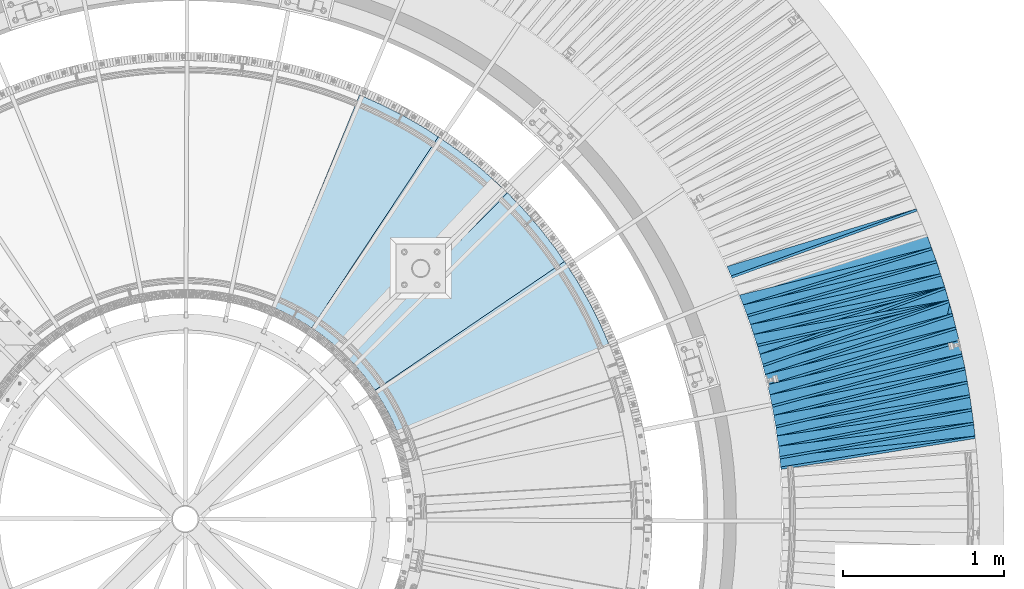
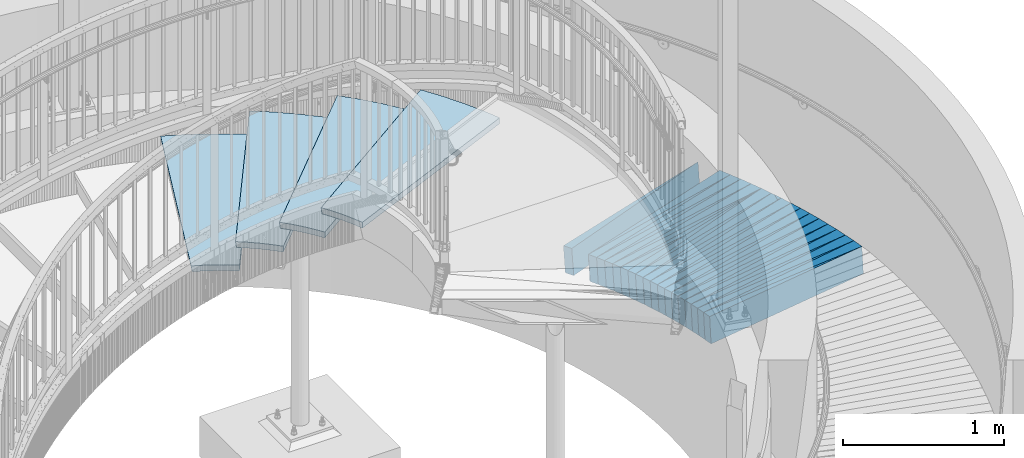
# One storey, part 835 of 975: 39 plates.
"""IFC2X3 building model written with IfcOpenShell, lengths in millimetres."""

from ifc_helpers import new_model, si_unit, frame, origin_with_axes, place, context, subcontext, project, spatial, faceted_brep, material, type_object, element, save


model = new_model("IFC2X3")

# Units and contexts
model_context = context("Model", 3, precision=1e-05, world=origin_with_axes())
body_context = subcontext(model_context, "Body", "Model", "MODEL_VIEW")
ifc_project = project(units=[si_unit("LENGTHUNIT", "METRE", prefix="MILLI"), si_unit("AREAUNIT", "SQUARE_METRE"), si_unit("VOLUMEUNIT", "CUBIC_METRE"), si_unit("MASSUNIT", "GRAM", prefix="KILO"), si_unit("TIMEUNIT", "SECOND"), si_unit("PLANEANGLEUNIT", "RADIAN"), si_unit("SOLIDANGLEUNIT", "STERADIAN"), si_unit("THERMODYNAMICTEMPERATUREUNIT", "DEGREE_CELSIUS"), si_unit("LUMINOUSINTENSITYUNIT", "LUMEN")], contexts=[model_context])

# Site, building, storey
site_placement = place(None, origin_with_axes())
site = spatial("IfcSite", under=ifc_project, at=site_placement, CompositionType="ELEMENT")
building_placement = place(site_placement, origin_with_axes())
building = spatial("IfcBuilding", under=site, at=building_placement, Name="Undefined", CompositionType="ELEMENT")
storey_placement = place(building_placement, origin_with_axes())
storey = spatial("IfcBuildingStorey", under=building, at=storey_placement, Name="Undefined", CompositionType="ELEMENT", Elevation=0.0)

# Plates
ifc_material_1 = material(Name="STEEL/A36")
plate_type_1 = type_object("IfcPlateType", PredefinedType="NOTDEFINED")
plate_1_placement = place(storey_placement, frame((39625.9824419077, 3998.43174738921, 426.0120271397), z_axis=(0.174232548959924, -0.983067229133674, 0.0567612710073381), x_axis=(-0.984686549821491, -0.174288045968404, 0.00400944299927316)))
element("IfcPlate", 1, at=plate_1_placement, inside=storey, type_object=plate_type_1, material=ifc_material_1, Name="SLAB", context=body_context, shape_type="Brep", body=[
    faceted_brep([(-6.82121026329696e-12, -100.000000000011, -1.09139364212751e-10), (6.05909538287233, -100.000000000004, 85.8984680175308), (6.05909538223204, 100.000000000001, 85.8984680176727), (5.91171556152403e-12, 100.000000000011, 1.09139364212751e-10), (1222.11474609037, -100.000000000009, 2.81397660728544e-09), (1222.11474608972, 99.9999999999958, 2.95494828606024e-09)], [[[0, 1, 2, 3]], [[1, 4, 5, 2]], [[4, 0, 3, 5]], [[5, 3, 2]], [[4, 1, 0]]]),
])
plate_2_placement = place(storey_placement, frame((39614.0804281054, 4083.64656523425, 421.111820499393), z_axis=(0.191444695794336, -0.979862872955085, 0.056724585996033), x_axis=(-0.981478928972378, -0.19152806399461, 0.00401406099988702)))
element("IfcPlate", 2, at=plate_2_placement, inside=storey, type_object=plate_type_1, material=ifc_material_1, Name="SLAB", context=body_context, shape_type="Brep", body=[
    faceted_brep([(-6.82121026329696e-12, -100.000000000011, -1.09139364212751e-10), (4.56011295288772, -100.000000000002, 86.0596008301241), (4.56011295317148, 100.0, 86.0596008300795), (5.91171556152403e-12, 100.000000000011, 1.09139364212751e-10), (1220.70886230643, -100.000000000039, -9.09949449123815e-10), (1220.70886230672, 99.9999999999637, -9.54059942159802e-10)], [[[0, 1, 2, 3]], [[1, 4, 5, 2]], [[4, 0, 3, 5]], [[5, 3, 2]], [[4, 1, 0]]]),
])
plate_3_placement = place(storey_placement, frame((39602.1949631265, 4168.745903443, 416.118423112002), z_axis=(0.208477679916396, -0.976313562950722, 0.0578695409964878), x_axis=(-0.977993776870184, -0.208593936972311, 0.00409168199945686)))
element("IfcPlate", 3, at=plate_3_placement, inside=storey, type_object=plate_type_1, material=ifc_material_1, Name="SLAB", context=body_context, shape_type="Brep", body=[
    faceted_brep([(-6.82121026329696e-12, -100.000000000011, -1.09139364212751e-10), (6.05673646894866, -99.9999999999937, 85.9729919434467), (6.05673646956711, 99.9999999999984, 85.9729919433266), (5.91171556152403e-12, 100.000000000011, 1.09139364212751e-10), (1221.99145507645, -99.9999999999583, 4.94401319883764e-09), (1221.99145507707, 100.000000000034, 4.82486939290538e-09)], [[[0, 1, 2, 3]], [[1, 4, 5, 2]], [[4, 0, 3, 5]], [[5, 3, 2]], [[4, 1, 0]]]),
])
plate_4_placement = place(storey_placement, frame((39587.3777138571, 4253.57169134227, 411.211967734843), z_axis=(0.225549249934069, -0.972577460815426, 0.0567504939890238), x_axis=(-0.974191077270086, -0.22568923806257, 0.00401407400111285)))
element("IfcPlate", 4, at=plate_4_placement, inside=storey, type_object=plate_type_1, material=ifc_material_1, Name="SLAB", context=body_context, shape_type="Brep", body=[
    faceted_brep([(-6.82121026329696e-12, -100.000000000011, -1.09139364212751e-10), (4.62010049822857, -100.0, 86.016075134231), (4.62010049857054, 99.9999999999967, 86.0160751341682), (5.91171556152403e-12, 100.000000000011, 1.09139364212751e-10), (1220.70507812274, -100.000000000071, -9.877112461254e-10), (1220.705078123, 99.9999999999361, -8.85847839526832e-10)], [[[0, 1, 2, 3]], [[1, 4, 5, 2]], [[4, 0, 3, 5]], [[5, 3, 2]], [[4, 1, 0]]]),
])
plate_5_placement = place(storey_placement, frame((39572.5968935966, 4338.06844142463, 406.218966547519), z_axis=(0.242357914820925, -0.968453872958731, 0.0579632389958235), x_axis=(-0.970134380603416, -0.242533594900854, 0.00409132199832751)))
element("IfcPlate", 5, at=plate_5_placement, inside=storey, type_object=plate_type_1, material=ifc_material_1, Name="SLAB", context=body_context, shape_type="Brep", body=[
    faceted_brep([(-6.82121026329696e-12, -100.000000000011, -1.09139364212751e-10), (6.08379650064307, -99.9999999999922, 85.8321456910589), (6.08379650125426, 100.000000000003, 85.8321456909125), (5.91171556152403e-12, 100.000000000011, 1.09139364212751e-10), (1222.09875488287, -99.9999999999768, 6.83940015733242e-10), (1222.09875488291, 100.000000000027, 8.29459168016911e-10)], [[[0, 1, 2, 3]], [[1, 4, 5, 2]], [[4, 0, 3, 5]], [[5, 3, 2]], [[4, 1, 0]]]),
])
plate_6_placement = place(storey_placement, frame((39554.79502433, 4422.19130410845, 401.218699276603), z_axis=(0.259235288096985, -0.964076087687476, 0.0579168589832336), x_axis=(-0.965750673638308, -0.259439509902835, 0.00409598199846596)))
element("IfcPlate", 6, at=plate_6_placement, inside=storey, type_object=plate_type_1, material=ifc_material_1, Name="SLAB", context=body_context, shape_type="Brep", body=[
    faceted_brep([(-6.82121026329696e-12, -100.000000000011, -1.09139364212751e-10), (4.55240583407249, -100.000000000034, 86.0086975093363), (4.55240583426712, 100.000000000015, 86.0086975099912), (5.91171556152403e-12, 100.000000000011, 1.09139364212751e-10), (1220.7084960928, -100.000000000221, -1.74622982740402e-09), (1220.708496093, 99.9999999998272, -1.09139364212751e-09)], [[[0, 1, 2, 3]], [[1, 4, 5, 2]], [[4, 0, 3, 5]], [[5, 3, 2]], [[4, 1, 0]]]),
])
plate_7_placement = place(storey_placement, frame((39536.9846772555, 4506.41710653635, 396.218264542999), z_axis=(0.276024998064779, -0.95940875384129, 0.057836350991757), x_axis=(-0.961075872682364, -0.276253055908699, 0.00417325399862075)))
element("IfcPlate", 7, at=plate_7_placement, inside=storey, type_object=plate_type_1, material=ifc_material_1, Name="SLAB", context=body_context, shape_type="Brep", body=[
    faceted_brep([(-6.82121026329696e-12, -100.000000000011, -1.09139364212751e-10), (6.07811546346784, -99.9999999999997, 86.012245178159), (6.07811546326411, 100.000000000002, 86.0122451782854), (5.91171556152403e-12, 100.000000000011, 1.09139364212751e-10), (1222.06787109673, -100.000000000031, 1.97815097635612e-09), (1222.06787109653, 99.9999999999707, 2.10366124520078e-09)], [[[0, 1, 2, 3]], [[1, 4, 5, 2]], [[4, 0, 3, 5]], [[5, 3, 2]], [[4, 1, 0]]]),
])
plate_8_placement = place(storey_placement, frame((39516.2599873774, 4589.94244293884, 391.312151865691), z_axis=(0.292758928776712, -0.954499123331264, 0.0567770480155632), x_axis=(-0.956101584764134, -0.293006799927716, 0.00409570599898962)))
element("IfcPlate", 8, at=plate_8_placement, inside=storey, type_object=plate_type_1, material=ifc_material_1, Name="SLAB", context=body_context, shape_type="Brep", body=[
    faceted_brep([(-6.82121026329696e-12, -100.000000000011, -1.09139364212751e-10), (4.56992292403447, -99.9999999999974, 85.9728164673306), (4.56992292365612, 100.000000000001, 85.9728164674088), (5.91171556152403e-12, 100.000000000011, 1.09139364212751e-10), (1220.7907714854, -99.999999999976, 2.13913153856993e-09), (1220.79077148502, 100.000000000022, 2.21643858822063e-09)], [[[0, 1, 2, 3]], [[1, 4, 5, 2]], [[4, 0, 3, 5]], [[5, 3, 2]], [[4, 1, 0]]]),
])
plate_9_placement = place(storey_placement, frame((39495.5906041289, 4673.36243128371, 386.318381136643), z_axis=(0.309347422665189, -0.949187086009158, 0.05786231799581), x_axis=(-0.950845544943423, -0.309638514981577, 0.00409141799975657)))
element("IfcPlate", 9, at=plate_9_placement, inside=storey, type_object=plate_type_1, material=ifc_material_1, Name="SLAB", context=body_context, shape_type="Brep", body=[
    faceted_brep([(-6.82121026329696e-12, -100.000000000011, -1.09139364212751e-10), (6.09768581410026, -100.000000000004, 85.9808578490283), (6.09768581418029, 100.000000000003, 85.9808578490811), (5.91171556152403e-12, 100.000000000011, 1.09139364212751e-10), (1222.07019043372, -100.000000000019, 8.43101588543504e-10), (1222.0701904338, 99.9999999999876, 8.95852281246334e-10)], [[[0, 1, 2, 3]], [[1, 4, 5, 2]], [[4, 0, 3, 5]], [[5, 3, 2]], [[4, 1, 0]]]),
])
plate_10_placement = place(storey_placement, frame((39471.9612434175, 4756.09113765538, 381.412225927542), z_axis=(0.325901786052775, -0.943696059324096, 0.0567958930186322), x_axis=(-0.945288728200497, -0.32621021906919, 0.00401413900085143)))
element("IfcPlate", 10, at=plate_10_placement, inside=storey, type_object=plate_type_1, material=ifc_material_1, Name="SLAB", context=body_context, shape_type="Brep", body=[
    faceted_brep([(-6.82121026329696e-12, -100.000000000011, -1.09139364212751e-10), (4.56129026379494, -100.000000000001, 85.9514694214504), (4.56129026418057, 99.9999999999982, 85.9514694213831), (5.91171556152403e-12, 100.000000000011, 1.09139364212751e-10), (1220.68530273628, -100.000000000019, 1.44973455462605e-09), (1220.68530273665, 99.9999999999799, 1.38061295729131e-09)], [[[0, 1, 2, 3]], [[1, 4, 5, 2]], [[4, 0, 3, 5]], [[5, 3, 2]], [[4, 1, 0]]]),
])
plate_11_placement = place(storey_placement, frame((39448.386584414, 4838.7133624584, 376.418469865489), z_axis=(0.342264877537244, -0.937819243784971, 0.057877625996593), x_axis=(-0.939467395749397, -0.342613882908607, 0.0040914009989086)))
element("IfcPlate", 11, at=plate_11_placement, inside=storey, type_object=plate_type_1, material=ifc_material_1, Name="SLAB", context=body_context, shape_type="Brep", body=[
    faceted_brep([(-6.82121026329696e-12, -100.000000000011, -1.09139364212751e-10), (6.08924770340673, -99.9999999999915, 85.9587173463115), (6.08924770363228, 99.9999999999977, 85.9587173461441), (5.91171556152403e-12, 100.000000000011, 1.09139364212751e-10), (1222.07543945396, -100.000000000037, -1.40244083013386e-09), (1222.07543945419, 99.999999999952, -1.56978785526007e-09)], [[[0, 1, 2, 3]], [[1, 4, 5, 2]], [[4, 0, 3, 5]], [[5, 3, 2]], [[4, 1, 0]]]),
])
plate_12_placement = place(storey_placement, frame((39472.2029686441, 4756.06143704428, 381.390397208628), z_axis=(0.22368990115793, -0.972939875342943, 0.057886329021748), x_axis=(-0.974512642012384, -0.22429519300285, -0.00409596800005203)))
element("IfcPlate", 12, at=plate_12_placement, inside=storey, type_object=plate_type_1, material=ifc_material_1, Name="SLAB", context=body_context, shape_type="Brep", body=[
    faceted_brep([(-6.82121026329696e-12, -100.000000000011, -1.09139364212751e-10), (-4.56721687257232, -100.000000000017, 86.0530090329958), (-4.56721687326353, 100.000000000002, 86.053009033214), (5.91171556152403e-12, 100.000000000011, 1.09139364212751e-10), (1220.71276855146, -99.9999999999328, -3.9744918467477e-10), (1220.71276855077, 100.000000000086, -1.79170456249267e-10)], [[[0, 1, 2, 3]], [[1, 4, 5, 2]], [[4, 0, 3, 5]], [[5, 3, 2]], [[4, 1, 0]]]),
])
plate_13_placement = place(storey_placement, frame((39448.5926548318, 4838.78714752327, 376.390536032474), z_axis=(0.240768893784589, -0.968852951319953, 0.0579163060317441), x_axis=(-0.970418033367917, -0.241397521091522, -0.00400965400152018)))
element("IfcPlate", 13, at=plate_13_placement, inside=storey, type_object=plate_type_1, material=ifc_material_1, Name="SLAB", context=body_context, shape_type="Brep", body=[
    faceted_brep([(-6.82121026329696e-12, -100.000000000011, -1.09139364212751e-10), (-3.05538058281672, -100.000000000003, 86.1199417113758), (-3.05538058237289, 99.9999999999897, 86.1199417113066), (5.91171556152403e-12, 100.000000000011, 1.09139364212751e-10), (1222.05065917552, -99.9999999999858, 4.12273948313668e-09), (1222.05065917598, 100.000000000007, 4.05361788580194e-09)], [[[0, 1, 2, 3]], [[1, 4, 5, 2]], [[4, 0, 3, 5]], [[5, 3, 2]], [[4, 1, 0]]]),
])
plate_14_placement = place(storey_placement, frame((39422.066176282, 4920.73525767463, 371.483793850987), z_axis=(0.257572832400976, -0.964591757229109, 0.0567360370011757), x_axis=(-0.966079833699057, -0.258211110919565, -0.00409598799872405)))
element("IfcPlate", 14, at=plate_14_placement, inside=storey, type_object=plate_type_1, material=ifc_material_1, Name="SLAB", context=body_context, shape_type="Brep", body=[
    faceted_brep([(-6.82121026329696e-12, -100.000000000011, -1.09139364212751e-10), (-4.59612512584135, -100.000000000003, 86.0330505371167), (-4.59612512593594, 99.9999999999959, 86.0330505370575), (5.91171556152403e-12, 100.000000000011, 1.09139364212751e-10), (1220.70654296677, -100.000000000073, 1.41517375595868e-09), (1220.70654296638, 99.9999999999, 1.13868736661971e-09)], [[[0, 1, 2, 3]], [[1, 4, 5, 2]], [[4, 0, 3, 5]], [[5, 3, 2]], [[4, 1, 0]]]),
])
plate_15_placement = place(storey_placement, frame((39395.5922700244, 5002.45462566311, 366.490597049088), z_axis=(0.27442047009075, -0.959863819145956, 0.0579211040097828), x_axis=(-0.96140465762622, -0.275107877893042, -0.00409143199840933)))
element("IfcPlate", 15, at=plate_15_placement, inside=storey, type_object=plate_type_1, material=ifc_material_1, Name="SLAB", context=body_context, shape_type="Brep", body=[
    faceted_brep([(-6.82121026329696e-12, -100.000000000011, -1.09139364212751e-10), (-3.08999657691311, -99.999999999991, 86.1060485840826), (-3.08999657622189, 99.9999999999988, 86.1060485839635), (5.91171556152403e-12, 100.000000000011, 1.09139364212751e-10), (1222.06604003649, -99.9999999999675, -8.78571881912649e-10), (1222.0660400372, 100.000000000023, -9.97715687844902e-10)], [[[0, 1, 2, 3]], [[1, 4, 5, 2]], [[4, 0, 3, 5]], [[5, 3, 2]], [[4, 1, 0]]]),
])
plate_16_placement = place(storey_placement, frame((39366.2791004726, 5083.28751788098, 361.490570024016), z_axis=(0.291006833646104, -0.954966010400153, 0.0579218590143898), x_axis=(-0.956496360066036, -0.291716644020139, -0.00401407300027713)))
element("IfcPlate", 16, at=plate_16_placement, inside=storey, type_object=plate_type_1, material=ifc_material_1, Name="SLAB", context=body_context, shape_type="Brep", body=[
    faceted_brep([(-6.82121026329696e-12, -100.000000000011, -1.09139364212751e-10), (-4.5703582764545, -99.999999999996, 86.0064620972498), (-4.57035827682557, 100.000000000005, 86.0064620972753), (5.91171556152403e-12, 100.000000000011, 1.09139364212751e-10), (1220.70507812274, -100.000000000071, -9.877112461254e-10), (1220.705078123, 99.9999999999361, -8.85847839526832e-10)], [[[0, 1, 2, 3]], [[1, 4, 5, 2]], [[4, 0, 3, 5]], [[5, 3, 2]], [[4, 1, 0]]]),
])
plate_17_placement = place(storey_placement, frame((39336.9385057262, 5164.23229206698, 356.584061502682), z_axis=(0.307720273152248, -0.949780613140639, 0.0567892630106877), x_axis=(-0.951237885653077, -0.308432173887512, -0.00400986399853756)))
element("IfcPlate", 17, at=plate_17_placement, inside=storey, type_object=plate_type_1, material=ifc_material_1, Name="SLAB", context=body_context, shape_type="Brep", body=[
    faceted_brep([(-6.82121026329696e-12, -100.000000000011, -1.09139364212751e-10), (-3.06472253797256, -99.9999999999985, 86.0675201415606), (-3.06472253784159, 99.9999999999941, 86.0675201415261), (5.91171556152403e-12, 100.000000000011, 1.09139364212751e-10), (1221.98669433537, -99.9999999999605, 4.74665284855291e-09), (1221.98669433551, 100.000000000032, 4.710273060482e-09)], [[[0, 1, 2, 3]], [[1, 4, 5, 2]], [[4, 0, 3, 5]], [[5, 3, 2]], [[4, 1, 0]]]),
])
plate_type_2 = type_object("IfcPlateType", PredefinedType="NOTDEFINED")
plate_18_placement = place(storey_placement, frame((39635.1936692544, 3910.9231824116, 431.047656661723), z_axis=(0.104275265094708, -0.991555543506223, 0.0770991130396971), x_axis=(-0.994515785968049, -0.10458657399664, 0.0)))
element("IfcPlate", 18, at=plate_18_placement, inside=storey, type_object=plate_type_2, material=ifc_material_1, Name="SLAB", context=body_context, shape_type="Brep", body=[
    faceted_brep([(-6.82121026329696e-12, -100.000000000011, -1.09139364212751e-10), (1219.04797363422, -100.000000000019, 64.8515853879779), (1219.04797363403, 99.9999999999873, 64.851585387998), (5.91171556152403e-12, 100.000000000011, 1.09139364212751e-10), (1219.08569336095, -100.00000000002, -8.19056822365383e-10), (1219.08569336076, 99.9999999999858, -7.98536348156631e-10)], [[[0, 1, 2, 3]], [[1, 4, 5, 2]], [[4, 0, 3, 5]], [[5, 3, 2]], [[4, 1, 0]]]),
])
plate_19_placement = place(storey_placement, frame((39626.3072442472, 3996.59952477286, 426.135234977188), z_axis=(0.121536557548468, -0.989713242079951, 0.0754755830110665), x_axis=(-0.992544325654003, -0.121884213957511, 0.0)))
element("IfcPlate", 19, at=plate_19_placement, inside=storey, type_object=plate_type_2, material=ifc_material_1, Name="SLAB", context=body_context, shape_type="Brep", body=[
    faceted_brep([(-6.82121026329696e-12, -100.000000000011, -1.09139364212751e-10), (1220.38916015246, -99.9999999999725, 64.9216613772952), (1220.38916015196, 100.000000000032, 64.9216613773524), (5.91171556152403e-12, 100.000000000011, 1.09139364212751e-10), (1219.18994140627, -100.000000000053, -7.20319803804159e-10), (1219.18994140625, 99.9999999999468, -8.36735125631094e-10)], [[[0, 1, 2, 3]], [[1, 4, 5, 2]], [[4, 0, 3, 5]], [[5, 3, 2]], [[4, 1, 0]]]),
])
plate_20_placement = place(storey_placement, frame((39614.4381807975, 4081.81586191426, 421.235302887626), z_axis=(0.138818678071955, -0.987436811432201, 0.0754845550226188), x_axis=(-0.990262057711787, -0.139215864959482, 0.0)))
element("IfcPlate", 20, at=plate_20_placement, inside=storey, type_object=plate_type_2, material=ifc_material_1, Name="SLAB", context=body_context, shape_type="Brep", body=[
    faceted_brep([(-6.82121026329696e-12, -100.000000000011, -1.09139364212751e-10), (1218.98168945343, -99.9999999999906, 64.9139404298153), (1218.98168945358, 100.00000000001, 64.9139404298273), (5.91171556152403e-12, 100.000000000011, 1.09139364212751e-10), (1218.97021484425, -99.9999999999932, -2.70483724307269e-09), (1218.9702148444, 100.000000000007, -2.69142219622154e-09)], [[[0, 1, 2, 3]], [[1, 4, 5, 2]], [[4, 0, 3, 5]], [[5, 3, 2]], [[4, 1, 0]]]),
])
plate_21_placement = place(storey_placement, frame((39602.5928489666, 4166.88293776894, 416.247106581318), z_axis=(0.156040928598268, -0.984742567447247, 0.0770279459650556), x_axis=(-0.987677020910883, -0.156505917985879, 0.0)))
element("IfcPlate", 21, at=plate_21_placement, inside=storey, type_object=plate_type_2, material=ifc_material_1, Name="SLAB", context=body_context, shape_type="Brep", body=[
    faceted_brep([(-6.82121026329696e-12, -100.000000000011, -1.09139364212751e-10), (1220.26611327869, -99.9999999999883, 64.9115066529448), (1220.26611327819, 100.000000000018, 64.9115066530658), (5.91171556152403e-12, 100.000000000011, 1.09139364212751e-10), (1219.12329101291, -99.9999999999872, 1.9990693544969e-09), (1219.12329101241, 100.00000000002, 2.1200321498327e-09)], [[[0, 1, 2, 3]], [[1, 4, 5, 2]], [[4, 0, 3, 5]], [[5, 3, 2]], [[4, 1, 0]]]),
])
plate_22_placement = place(storey_placement, frame((39587.7994994513, 4251.75324628954, 411.335603814503), z_axis=(0.173246999798132, -0.981978389669941, 0.0755242959727249), x_axis=(-0.984790990276387, -0.173743217048762, 0.0)))
element("IfcPlate", 22, at=plate_22_placement, inside=storey, type_object=plate_type_2, material=ifc_material_1, Name="SLAB", context=body_context, shape_type="Brep", body=[
    faceted_brep([(-6.82121026329696e-12, -100.000000000011, -1.09139364212751e-10), (1218.97973632623, -100.000000000001, 64.8797836303711), (1218.97973632606, 99.9999999999978, 64.879783630357), (5.91171556152403e-12, 100.000000000011, 1.09139364212751e-10), (1219.04040527135, -99.9999999999979, 3.58977558789775e-09), (1219.04040527118, 100.000000000001, 3.57613316737115e-09)], [[[0, 1, 2, 3]], [[1, 4, 5, 2]], [[4, 0, 3, 5]], [[5, 3, 2]], [[4, 1, 0]]]),
])
plate_23_placement = place(storey_placement, frame((39573.0558259939, 4336.23486631698, 406.3466842114), z_axis=(0.190215824337771, -0.978720112202225, 0.0769732560203004), x_axis=(-0.981632460760012, -0.190781843953358, 0.0)))
element("IfcPlate", 23, at=plate_23_placement, inside=storey, type_object=plate_type_2, material=ifc_material_1, Name="SLAB", context=body_context, shape_type="Brep", body=[
    faceted_brep([(-6.82121026329696e-12, -100.000000000011, -1.09139364212751e-10), (1220.37121581964, -100.000000000275, 64.9576263392737), (1220.3712158196, 99.9999999997194, 64.9576263391209), (5.91171556152403e-12, 100.000000000011, 1.09139364212751e-10), (1219.19360351495, -100.00000000027, -7.08678271621466e-09), (1219.19360351492, 99.9999999997235, -7.23230186849833e-09)], [[[0, 1, 2, 3]], [[1, 4, 5, 2]], [[4, 0, 3, 5]], [[5, 3, 2]], [[4, 1, 0]]]),
])
plate_24_placement = place(storey_placement, frame((39555.2485426552, 4420.50494634474, 401.3353492434), z_axis=(0.207283429834701, -0.975363903392586, 0.0754906330264907), x_axis=(-0.978156345823696, -0.207870527962532, 8.20329999852089e-05)))
element("IfcPlate", 24, at=plate_24_placement, inside=storey, type_object=plate_type_2, material=ifc_material_1, Name="SLAB", context=body_context, shape_type="Brep", body=[
    faceted_brep([(-6.82121026329696e-12, -100.000000000011, -1.09139364212751e-10), (1218.98156738237, -100.000000000005, 64.9087677006019), (1218.98156738291, 99.9999999999862, 64.9087677004409), (5.91171556152403e-12, 100.000000000011, 1.09139364212751e-10), (1219.02807616998, -100.0, -6.25732354819775e-10), (1219.02807616998, 100.0, -6.25732354819775e-10)], [[[0, 1, 2, 3]], [[1, 4, 5, 2]], [[4, 0, 3, 5]], [[5, 3, 2]], [[4, 1, 0]]]),
])
plate_25_placement = place(storey_placement, frame((39537.5123529006, 4504.58328601841, 396.3471348594), z_axis=(0.224310998257453, -0.971468329136015, 0.0770315620146961), x_axis=(-0.974364921798821, -0.224973314953549, 8.20169999830688e-05)))
element("IfcPlate", 25, at=plate_25_placement, inside=storey, type_object=plate_type_2, material=ifc_material_1, Name="SLAB", context=body_context, shape_type="Brep", body=[
    faceted_brep([(-6.82121026329696e-12, -100.000000000011, -1.09139364212751e-10), (1220.34301757949, -100.000000000041, 64.9073028563771), (1220.34301757914, 99.999999999971, 64.9073028565372), (5.91171556152403e-12, 100.000000000011, 1.09139364212751e-10), (1219.25573730616, -100.000000000041, -3.66890162695199e-09), (1219.25573730582, 99.9999999999716, -3.50883055943996e-09)], [[[0, 1, 2, 3]], [[1, 4, 5, 2]], [[4, 0, 3, 5]], [[5, 3, 2]], [[4, 1, 0]]]),
])
plate_26_placement = place(storey_placement, frame((39516.8510490228, 4588.01565535995, 391.447198894502), z_axis=(0.241198931711602, -0.967413009126454, 0.0770398930040898), x_axis=(-0.970296720224289, -0.24191790905592, 0.0)))
element("IfcPlate", 26, at=plate_26_placement, inside=storey, type_object=plate_type_2, material=ifc_material_1, Name="SLAB", context=body_context, shape_type="Brep", body=[
    faceted_brep([(-6.82121026329696e-12, -100.000000000011, -1.09139364212751e-10), (1219.06433105493, -100.00000000003, 64.9014434810633), (1219.06433105533, 99.9999999999663, 64.9014434810188), (5.91171556152403e-12, 100.000000000011, 1.09139364212751e-10), (1219.0085449224, -99.9999999998281, 1.32422428578138e-09), (1219.00854492224, 100.000000000115, 6.83940015733242e-10)], [[[0, 1, 2, 3]], [[1, 4, 5, 2]], [[4, 0, 3, 5]], [[5, 3, 2]], [[4, 1, 0]]]),
])
plate_27_placement = place(storey_placement, frame((39496.1819606158, 4671.54818273382, 386.447298540808), z_axis=(0.258097673342534, -0.963041255022485, 0.0770527880085311), x_axis=(-0.965912899963065, -0.258867281990101, 0.0)))
element("IfcPlate", 27, at=plate_27_placement, inside=storey, type_object=plate_type_2, material=ifc_material_1, Name="SLAB", context=body_context, shape_type="Brep", body=[
    faceted_brep([(-6.82121026329696e-12, -100.000000000011, -1.09139364212751e-10), (1220.34619140562, -99.9999999999754, 64.8905792239475), (1220.34619140623, 100.000000000008, 64.8905792237292), (5.91171556152403e-12, 100.000000000011, 1.09139364212751e-10), (1219.15759277291, -99.9999999999769, 3.51610651705414e-09), (1219.15759277353, 100.000000000006, 3.29600879922509e-09)], [[[0, 1, 2, 3]], [[1, 4, 5, 2]], [[4, 0, 3, 5]], [[5, 3, 2]], [[4, 1, 0]]]),
])
plate_28_placement = place(storey_placement, frame((39472.5680443613, 4754.33427089206, 381.535341117535), z_axis=(0.274844618962044, -0.958520607483401, 0.0754896049616134), x_axis=(-0.961263487490899, -0.275631107854022, 0.0)))
element("IfcPlate", 28, at=plate_28_placement, inside=storey, type_object=plate_type_2, material=ifc_material_1, Name="SLAB", context=body_context, shape_type="Brep", body=[
    faceted_brep([(-6.82121026329696e-12, -100.000000000011, -1.09139364212751e-10), (1218.9582519566, -100.000000000099, 64.9095993028868), (1218.95825195598, 99.9999999999152, 64.9095993030733), (5.91171556152403e-12, 100.000000000011, 1.09139364212751e-10), (1219.02062988339, -99.9999999998413, 1.29512045532465e-09), (1219.02062988328, 100.000000000125, 9.24046617001295e-10)], [[[0, 1, 2, 3]], [[1, 4, 5, 2]], [[4, 0, 3, 5]], [[5, 3, 2]], [[4, 1, 0]]]),
])
plate_29_placement = place(storey_placement, frame((39449.0407947805, 4836.92101887284, 376.547402248943), z_axis=(0.291538530570673, -0.953449571335395, 0.0770662060376899), x_axis=(-0.956293610011188, -0.292408159003421, 0.0)))
element("IfcPlate", 29, at=plate_29_placement, inside=storey, type_object=plate_type_2, material=ifc_material_1, Name="SLAB", context=body_context, shape_type="Brep", body=[
    faceted_brep([(-6.82121026329696e-12, -100.000000000011, -1.09139364212751e-10), (1220.35205078238, -100.000000000015, 64.8792800901138), (1220.35205078232, 99.9999999999918, 64.879280090222), (5.91171556152403e-12, 100.000000000011, 1.09139364212751e-10), (1219.18627929667, -100.000000000066, 4.07453626394272e-10), (1219.18627929667, 99.9999999999281, 3.85625753551722e-10)], [[[0, 1, 2, 3]], [[1, 4, 5, 2]], [[4, 0, 3, 5]], [[5, 3, 2]], [[4, 1, 0]]]),
])
plate_30_placement = place(storey_placement, frame((39449.0499619025, 4836.94664507121, 376.518652140778), z_axis=(0.188858267142903, -0.979015209366442, 0.0765622280302822), x_axis=(-0.981747961655433, -0.190015734933309, -0.00805979299717122)))
element("IfcPlate", 30, at=plate_30_placement, inside=storey, type_object=plate_type_2, material=ifc_material_1, Name="SLAB", context=body_context, shape_type="Brep", body=[
    faceted_brep([(-6.82121026329696e-12, -100.000000000011, -1.09139364212751e-10), (1220.34899902174, -99.9999999999044, 64.4673156746703), (1220.34899902165, 100.000000000095, 64.4673156746162), (5.91171556152403e-12, 100.000000000011, 1.09139364212751e-10), (1228.31933593596, -99.9999999999067, -4.36557456851006e-11), (1228.31933593586, 100.000000000093, -9.77706804405898e-11)], [[[0, 1, 2, 3]], [[1, 4, 5, 2]], [[4, 0, 3, 5]], [[5, 3, 2]], [[4, 1, 0]]]),
])
plate_31_placement = place(storey_placement, frame((39396.070368202, 5000.78211443057, 366.606742668998), z_axis=(0.222919618728287, -0.971947821984357, 0.0749951660168798), x_axis=(-0.974525309259415, -0.224132680059664, -0.00805998400214553)))
element("IfcPlate", 31, at=plate_31_placement, inside=storey, type_object=plate_type_2, material=ifc_material_1, Name="SLAB", context=body_context, shape_type="Brep", body=[
    faceted_brep([(-6.82121026329696e-12, -100.000000000011, -1.09139364212751e-10), (1220.3635253946, -100.000000000103, 64.4856185901835), (1220.36352539395, 99.9999999999128, 64.4856185902686), (5.91171556152403e-12, 100.000000000011, 1.09139364212751e-10), (1228.29028320695, -100.000000000096, -4.76802597404458e-09), (1228.2902832063, 99.999999999919, -4.68162397737615e-09)], [[[0, 1, 2, 3]], [[1, 4, 5, 2]], [[4, 0, 3, 5]], [[5, 3, 2]], [[4, 1, 0]]]),
])
plate_32_placement = place(storey_placement, frame((39273.417529656, 5321.91595553617, 346.819353142491), z_axis=(0.290147493871111, -0.953907745039271, 0.0766449329989017), x_axis=(-0.956508001392885, -0.291592482119772, -0.00814049400334372)))
element("IfcPlate", 32, at=plate_32_placement, inside=storey, type_object=plate_type_2, material=ifc_material_1, Name="SLAB", context=body_context, shape_type="Brep", body=[
    faceted_brep([(-6.82121026329696e-12, -100.000000000011, -1.09139364212751e-10), (1220.46301269531, -99.9999999999969, 64.3900527956675), (1220.46301269505, 100.000000000012, 64.3900527957712), (5.91171556152403e-12, 100.000000000011, 1.09139364212751e-10), (1228.42675781243, -99.9999999999951, 3.34512151312083e-09), (1228.42675781217, 100.000000000013, 3.4469849197194e-09)], [[[0, 1, 2, 3]], [[1, 4, 5, 2]], [[4, 0, 3, 5]], [[5, 3, 2]], [[4, 1, 0]]]),
])
plate_type_3 = type_object("IfcPlateType", PredefinedType="NOTDEFINED")
plate_33_placement = place(storey_placement, frame((39472.5972379869, 4754.34627656004, 381.508023365879), z_axis=(0.171784286933791, -0.98226287725732, 0.0751651430173585), x_axis=(-0.984912620515893, -0.172864541090545, -0.00806104100422235)))
element("IfcPlate", 33, at=plate_33_placement, inside=storey, type_object=plate_type_3, material=ifc_material_1, Name="SLAB", context=body_context, shape_type="Brep", body=[
    faceted_brep([(-6.82121026329696e-12, -100.000000000011, -1.09139364212751e-10), (1219.02270507738, -99.9999999999975, 64.2131652831049), (1219.02270507767, 99.999999999989, 64.2131652830089), (5.91171556152403e-12, 100.000000000011, 1.09139364212751e-10), (1228.12927246015, -99.9999999999943, 9.16770659387112e-10), (1228.12927246043, 99.9999999999923, 8.21728463051841e-10)], [[[0, 1, 2, 3]], [[1, 4, 5, 2]], [[4, 0, 3, 5]], [[5, 3, 2]], [[4, 1, 0]]]),
])
plate_34_placement = place(storey_placement, frame((39422.5878404751, 4918.78133608765, 371.619294193843), z_axis=(0.205923224283164, -0.975562597833308, 0.0766370889945102), x_axis=(-0.978278259824884, -0.207136070962922, -0.00814214099854256)))
element("IfcPlate", 34, at=plate_34_placement, inside=storey, type_object=plate_type_3, material=ifc_material_1, Name="SLAB", context=body_context, shape_type="Brep", body=[
    faceted_brep([(-6.82121026329696e-12, -100.000000000011, -1.09139364212751e-10), (1219.01354980731, -100.000000000041, 64.2688903808171), (1219.01354980678, 99.9999999999687, 64.2688903808771), (5.91171556152403e-12, 100.000000000011, 1.09139364212751e-10), (1228.17822265887, -100.00000000004, 3.22643245453946e-09), (1228.17822265835, 99.9999999999698, 3.28691385220736e-09)], [[[0, 1, 2, 3]], [[1, 4, 5, 2]], [[4, 0, 3, 5]], [[5, 3, 2]], [[4, 1, 0]]]),
])
plate_35_placement = place(storey_placement, frame((39366.7902634345, 5081.60987596492, 361.607796890952), z_axis=(0.239853781051977, -0.967896472486196, 0.0751437440100552), x_axis=(-0.97046502774977, -0.241109828937832, -0.00797999399794241)))
element("IfcPlate", 35, at=plate_35_placement, inside=storey, type_object=plate_type_3, material=ifc_material_1, Name="SLAB", context=body_context, shape_type="Brep", body=[
    faceted_brep([(-6.82121026329696e-12, -100.000000000011, -1.09139364212751e-10), (1219.01330566303, -99.9999999999991, 64.2464523315839), (1219.01330566328, 99.9999999999902, 64.2464523314375), (5.91171556152403e-12, 100.000000000011, 1.09139364212751e-10), (1228.07104492081, -99.9999999999977, -2.5365807232447e-09), (1228.07104492104, 99.9999999999914, -2.68209987552837e-09)], [[[0, 1, 2, 3]], [[1, 4, 5, 2]], [[4, 0, 3, 5]], [[5, 3, 2]], [[4, 1, 0]]]),
])
ifc_material_2 = material(Name="STEEL/Zero_Density")
plate_type_4 = type_object("IfcPlateType", PredefinedType="NOTDEFINED")
for number, where, z_axis, x_axis, name in (
    (36, (35911.2608851843, 4202.73307459513, 1933.575), (0.85610277274309, 0.51680561384489, 0.0), (0.516805613844891, -0.856102772743089, 0.0), "CONC."),
    (37, (35734.266526025, 4415.45312434738, 1755.775), (0.739839892974219, 0.672782975976575, 0.0), (0.672782975976574, -0.739839892974219, 0.0), "CONC."),
    (38, (35519.4350084215, 4589.87858632191, 1577.975), (0.595577037387548, 0.80329819652273, 0.0), (0.803298196522731, -0.595577037387547, 0.0), "CONC."),
    (39, (35274.8968448074, 4719.40815544434, 1400.175), (0.428773976158555, 0.903411798334062, 0.0), (0.903411798334061, -0.428773976158555, 0.0), "CONC."),
):
    element("IfcPlate", number, at=place(storey_placement, frame(where, z_axis=z_axis, x_axis=x_axis)), inside=storey, type_object=plate_type_4, material=ifc_material_2, Name=name, context=body_context, shape_type="Brep", body=[
        faceted_brep([(226.607026755963, -22.2249999999999, -5.9806827134089), (151.21244687953, -22.2249999999999, 0.0171956564081484), (151.21244687953, 22.2249999999999, 0.0171956564081484), (226.607026755963, 22.2249999999999, -5.9806827134089), (75.6059955448145, -22.2249999999999, 2.01262449634305), (75.6059955448145, 22.2249999999999, 2.01262449634305), (0.0, -22.2249999999999, 0.0), (6.3512526843333, 22.2249999999999, 0.169069749597838), (-75.9923477177144, -22.2249999999999, 1420.59179687598), (-69.6411756631605, 22.2249999999999, 1420.76237488879), (75.2887648406067, -22.2249999999999, 1424.6548629265), (75.2887648406067, 22.2249999999999, 1424.6548629265), (226.570657118533, -22.2249999999999, 1420.62093290526), (226.570657118533, 22.2249999999999, 1420.62093290526), (377.420264969449, -22.2249999999999, 1408.50155446305), (377.420264969449, 22.2249999999999, 1408.50155446305), (501.974970329931, -22.2249999999999, 1391.75136796272), (501.974970329931, 22.2249999999999, 1391.75136796272), (301.578002929167, 22.2249999999999, -15.9641666403222), (301.578002929167, -22.2249999999999, -15.9641666403222)], [[[0, 1, 2, 3]], [[1, 4, 5, 2]], [[5, 4, 6, 7]], [[8, 9, 7, 6]], [[10, 11, 9, 8]], [[10, 12, 13, 11]], [[12, 14, 15, 13]], [[15, 14, 16, 17]], [[3, 2, 5, 7, 9, 11, 13, 15, 17, 18]], [[0, 3, 18, 19]], [[14, 12, 10, 8, 6, 4, 1, 0, 19, 16]], [[18, 17, 16, 19]]]),
    ])

save(model, "model.ifc")
